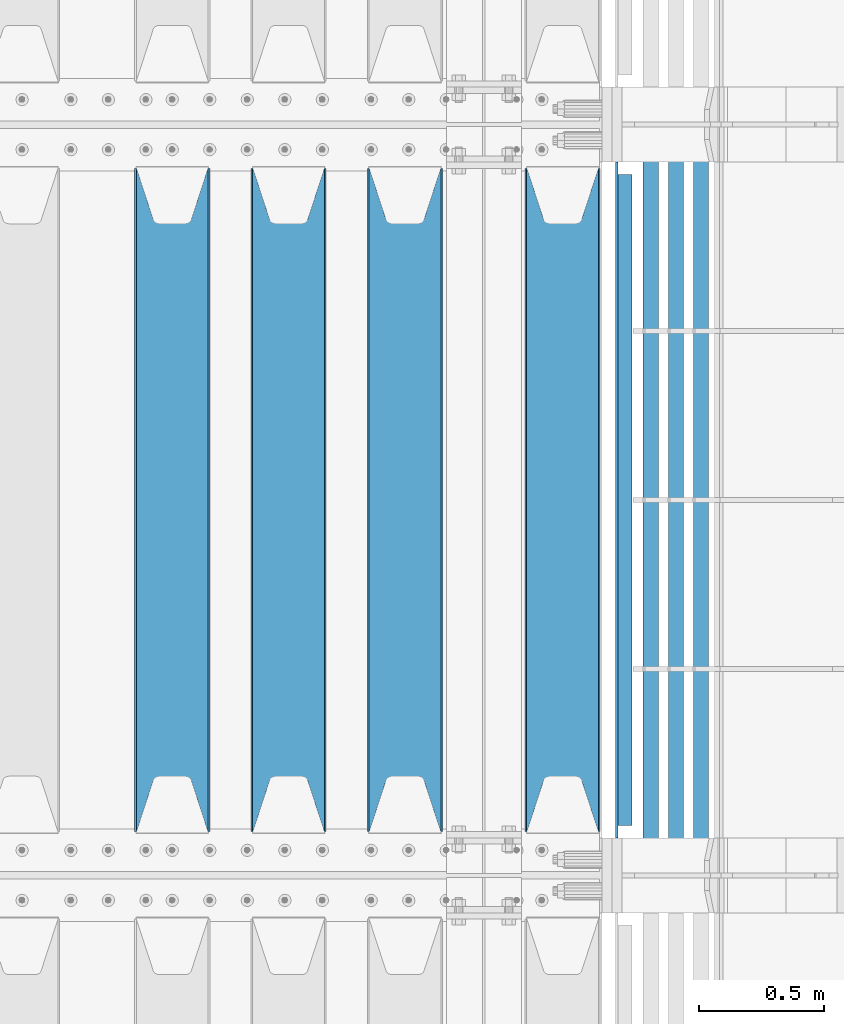
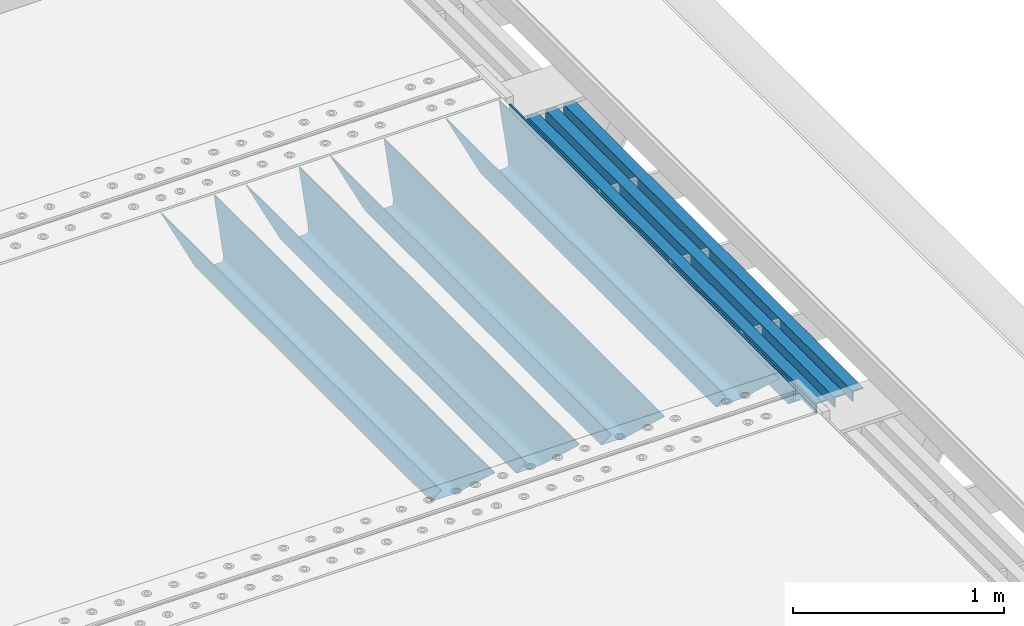
# One storey, part 132 of 247: 8 beams.
"""IFC2X3 building model written with IfcOpenShell, lengths in millimetres."""

from ifc_helpers import new_model, si_unit, frame, origin_with_axes, place, context, subcontext, project, spatial, faceted_brep, material, type_object, element, save


model = new_model("IFC2X3")

# Units and contexts
model_context = context("Model", 3, precision=1e-05, world=origin_with_axes())
body_context = subcontext(model_context, "Body", "Model", "MODEL_VIEW")
ifc_project = project(units=[si_unit("LENGTHUNIT", "METRE", prefix="MILLI"), si_unit("AREAUNIT", "SQUARE_METRE"), si_unit("VOLUMEUNIT", "CUBIC_METRE"), si_unit("MASSUNIT", "GRAM", prefix="KILO"), si_unit("TIMEUNIT", "SECOND"), si_unit("PLANEANGLEUNIT", "RADIAN"), si_unit("SOLIDANGLEUNIT", "STERADIAN"), si_unit("THERMODYNAMICTEMPERATUREUNIT", "DEGREE_CELSIUS"), si_unit("LUMINOUSINTENSITYUNIT", "LUMEN")], contexts=[model_context])

# Site, building, storey
site_placement = place(None, origin_with_axes())
site = spatial("IfcSite", under=ifc_project, at=site_placement, CompositionType="ELEMENT")
building_placement = place(site_placement, origin_with_axes())
building = spatial("IfcBuilding", under=site, at=building_placement, Name="Standard", CompositionType="ELEMENT")
storey_placement = place(building_placement, origin_with_axes())
storey = spatial("IfcBuildingStorey", under=building, at=storey_placement, Name="Undefined", CompositionType="ELEMENT", Elevation=0.0)

# Beams
ifc_material_1 = material(Name="STEEL/S355N")
beam_type_1 = type_object("IfcBeamType", PredefinedType="NOTDEFINED")
beam_1_placement = place(storey_placement, frame((16660.0, 3175.0, -115.0), z_axis=(0.0, 0.0, 1.0), x_axis=(0.0, 1.0, 0.0)))
element("IfcBeam", 1, at=beam_1_placement, inside=storey, type_object=beam_type_1, material=ifc_material_1, context=body_context, shape_type="Brep", body=[
    faceted_brep([(0.0, 150.0, 115.0), (0.0, 143.689999999999, 115.0), (2650.00000000297, 143.689999999999, 115.0), (2650.00000000297, 150.0, 115.0), (2650.00000000297, 142.059565218402, 110.0000000031), (2650.00000000297, 148.369565218403, 110.0000000031), (2441.90079219208, -80.1103600731112, -98.0992078077845), (2437.7588105432, -77.5672621345584, -102.241189456673), (2434.06523489746, -74.4080125315522, -105.934765102404), (2430.91086095089, -70.710272125576, -109.089139048974), (2428.37322971128, -66.5649389910068, -111.626770288588), (2426.51472138054, -62.0739139532889, -113.485278619323), (2425.38102192091, -57.3475956567672, -114.618978078955), (2424.99999999987, -52.5021667386536, -115.0), (2424.99999999987, 52.5021667386536, -115.0), (2425.38102192091, 57.3475956567672, -114.618978078955), (2426.51472138054, 62.0739139532889, -113.485278619323), (2428.37322971128, 66.5649389910068, -111.626770288588), (2430.91086095089, 70.710272125576, -109.089139048974), (2434.06523489746, 74.4080125315522, -105.934765102404), (2437.7588105432, 77.5672621345584, -102.241189456673), (2441.90079219208, 80.1103600731112, -98.0992078077846), (2446.38936140511, 81.9747917625791, -93.6106385947584), (2448.24948500409, 76.2713538057251, -91.7505149957729), (2444.62967112262, 74.76777986261, -95.3703288772456), (2441.28936334126, 72.7168944282894, -98.710636658607), (2438.31067330438, 70.1691124903846, -101.689326695487), (2435.76682334747, 67.1870637758839, -104.233176652398), (2433.72034654133, 63.8440531834895, -106.279653458539), (2432.22154950041, 60.222258798236, -107.778450499454), (2431.30727574265, 56.4107117849089, -108.692724257221), (2430.99999999987, 52.5031078186876, -109.0), (2430.99999999987, -52.5031078186876, -109.0), (2431.30727574265, -56.4107117849089, -108.692724257221), (2432.22154950041, -60.222258798236, -107.778450499454), (2433.72034654133, -63.8440531834895, -106.279653458539), (2435.76682334747, -67.1870637758839, -104.233176652398), (2438.31067330438, -70.1691124903846, -101.689326695487), (2441.28936334126, -72.7168944282894, -98.7106366586071), (2444.62967112262, -74.76777986261, -95.3703288772457), (2448.24948500409, -76.2713538057251, -91.7505149957729), (2650.00000000297, -142.059565218402, 110.0000000031), (2650.00000000297, -148.369565218403, 110.0000000031), (2446.38936140511, -81.9747917625791, -93.6106385947584), (2650.00000000297, -143.689999999999, 115.0), (2650.00000000297, -150.0, 115.0), (0.0, -143.689999999999, 115.0), (0.0, -150.0, 115.0), (0.0, -148.369565218261, 110.000000002663), (203.610638597422, -81.9747917625791, -93.6106385947584), (208.099207810448, -80.1103600731112, -98.0992078077845), (212.241189459336, -77.5672621345584, -102.241189456673), (215.934765105068, -74.4080125315522, -105.934765102404), (219.089139051637, -70.710272125576, -109.089139048974), (221.626770291251, -66.5649389910068, -111.626770288588), (223.485278621985, -62.0739139532889, -113.485278619323), (224.618978081617, -57.3475956567672, -114.618978078955), (225.000000002663, -52.5021667386536, -115.0), (225.000000002663, 52.5021667386536, -115.0), (224.618978081617, 57.3475956567672, -114.618978078955), (223.485278621985, 62.0739139532889, -113.485278619323), (221.626770291251, 66.5649389910068, -111.626770288588), (219.089139051637, 70.710272125576, -109.089139048974), (215.934765105068, 74.4080125315522, -105.934765102404), (212.241189459336, 77.5672621345584, -102.241189456673), (208.099207810448, 80.1103600731112, -98.0992078077846), (203.610638597422, 81.9747917625791, -93.6106385947584), (0.0, 148.369565218261, 110.000000002663), (0.0, 142.05956521826, 110.000000002663), (201.750514998436, 76.2713538057251, -91.7505149957729), (205.370328879908, 74.76777986261, -95.3703288772456), (208.710636661271, 72.7168944282894, -98.710636658607), (211.68932669815, 70.1691124903846, -101.689326695487), (214.233176655061, 67.1870637758839, -104.233176652398), (216.279653461202, 63.8440531834895, -106.279653458539), (217.778450502117, 60.222258798236, -107.778450499454), (218.692724259885, 56.4107117849089, -108.692724257221), (219.000000002663, 52.5031078186876, -109.0), (219.000000002663, -52.5031078186876, -109.0), (218.692724259885, -56.4107117849089, -108.692724257221), (217.778450502117, -60.222258798236, -107.778450499454), (216.279653461202, -63.8440531834895, -106.279653458539), (214.233176655061, -67.1870637758839, -104.233176652398), (211.68932669815, -70.1691124903846, -101.689326695487), (208.710636661271, -72.7168944282894, -98.7106366586071), (205.370328879908, -74.76777986261, -95.3703288772457), (201.750514998436, -76.2713538057251, -91.7505149957729), (0.0, -142.05956521826, 110.000000002663)], [[[0, 1, 2, 3]], [[3, 2, 4, 5]], [[6, 7, 8, 9, 10, 11, 12, 13, 14, 15, 16, 17, 18, 19, 20, 21, 22, 5, 4, 23, 24, 25, 26, 27, 28, 29, 30, 31, 32, 33, 34, 35, 36, 37, 38, 39, 40, 41, 42, 43]], [[44, 45, 42, 41]], [[46, 47, 45, 44]], [[43, 42, 45, 47, 48, 49]], [[6, 43, 49, 50]], [[7, 6, 50, 51]], [[8, 7, 51, 52]], [[9, 8, 52, 53]], [[10, 9, 53, 54]], [[11, 10, 54, 55]], [[12, 11, 55, 56]], [[13, 12, 56, 57]], [[14, 13, 57, 58]], [[15, 14, 58, 59]], [[16, 15, 59, 60]], [[17, 16, 60, 61]], [[18, 17, 61, 62]], [[19, 18, 62, 63]], [[20, 19, 63, 64]], [[21, 20, 64, 65]], [[22, 21, 65, 66]], [[0, 3, 5, 22, 66, 67]], [[1, 0, 67, 68]], [[23, 4, 2, 1, 68, 69]], [[24, 23, 69, 70]], [[25, 24, 70, 71]], [[26, 25, 71, 72]], [[27, 26, 72, 73]], [[28, 27, 73, 74]], [[29, 28, 74, 75]], [[30, 29, 75, 76]], [[31, 30, 76, 77]], [[32, 31, 77, 78]], [[33, 32, 78, 79]], [[34, 33, 79, 80]], [[35, 34, 80, 81]], [[36, 35, 81, 82]], [[37, 36, 82, 83]], [[38, 37, 83, 84]], [[39, 38, 84, 85]], [[40, 39, 85, 86]], [[46, 44, 41, 40, 86, 87]], [[47, 46, 87, 48]], [[86, 85, 84, 83, 82, 81, 80, 79, 78, 77, 76, 75, 74, 73, 72, 71, 70, 69, 68, 67, 66, 65, 64, 63, 62, 61, 60, 59, 58, 57, 56, 55, 54, 53, 52, 51, 50, 49, 48, 87]]]),
])
beam_2_placement = place(storey_placement, frame((16030.0, 3175.0, -115.0), z_axis=(0.0, 0.0, 1.0), x_axis=(0.0, 1.0, 0.0)))
element("IfcBeam", 2, at=beam_2_placement, inside=storey, type_object=beam_type_1, material=ifc_material_1, context=body_context, shape_type="Brep", body=[
    faceted_brep([(0.0, 150.0, 115.0), (0.0, 143.689999999999, 115.0), (2650.00000000297, 143.689999999999, 115.0), (2650.00000000297, 150.0, 115.0), (2650.00000000297, 142.059565218402, 110.0000000031), (2650.00000000297, 148.369565218403, 110.0000000031), (2441.90079219208, -80.1103600731112, -98.0992078077845), (2437.7588105432, -77.5672621345584, -102.241189456673), (2434.06523489746, -74.4080125315522, -105.934765102404), (2430.91086095089, -70.710272125576, -109.089139048974), (2428.37322971128, -66.5649389910068, -111.626770288588), (2426.51472138054, -62.0739139532889, -113.485278619323), (2425.38102192091, -57.3475956567672, -114.618978078955), (2424.99999999987, -52.5021667386536, -115.0), (2424.99999999987, 52.5021667386536, -115.0), (2425.38102192091, 57.3475956567672, -114.618978078955), (2426.51472138054, 62.0739139532889, -113.485278619323), (2428.37322971128, 66.5649389910068, -111.626770288588), (2430.91086095089, 70.710272125576, -109.089139048974), (2434.06523489746, 74.4080125315522, -105.934765102404), (2437.7588105432, 77.5672621345584, -102.241189456673), (2441.90079219208, 80.1103600731112, -98.0992078077846), (2446.38936140511, 81.9747917625791, -93.6106385947584), (2448.24948500409, 76.2713538057251, -91.7505149957729), (2444.62967112262, 74.76777986261, -95.3703288772456), (2441.28936334126, 72.7168944282894, -98.710636658607), (2438.31067330438, 70.1691124903846, -101.689326695487), (2435.76682334747, 67.1870637758839, -104.233176652398), (2433.72034654133, 63.8440531834895, -106.279653458539), (2432.22154950041, 60.222258798236, -107.778450499454), (2431.30727574265, 56.4107117849089, -108.692724257221), (2430.99999999987, 52.5031078186876, -109.0), (2430.99999999987, -52.5031078186876, -109.0), (2431.30727574265, -56.4107117849089, -108.692724257221), (2432.22154950041, -60.222258798236, -107.778450499454), (2433.72034654133, -63.8440531834895, -106.279653458539), (2435.76682334747, -67.1870637758839, -104.233176652398), (2438.31067330438, -70.1691124903846, -101.689326695487), (2441.28936334126, -72.7168944282894, -98.7106366586071), (2444.62967112262, -74.76777986261, -95.3703288772457), (2448.24948500409, -76.2713538057251, -91.7505149957729), (2650.00000000297, -142.059565218402, 110.0000000031), (2650.00000000297, -148.369565218403, 110.0000000031), (2446.38936140511, -81.9747917625791, -93.6106385947584), (2650.00000000297, -143.689999999999, 115.0), (2650.00000000297, -150.0, 115.0), (0.0, -143.689999999999, 115.0), (0.0, -150.0, 115.0), (0.0, -148.369565218261, 110.000000002663), (203.610638597422, -81.9747917625791, -93.6106385947584), (208.099207810448, -80.1103600731112, -98.0992078077845), (212.241189459336, -77.5672621345584, -102.241189456673), (215.934765105068, -74.4080125315522, -105.934765102404), (219.089139051637, -70.710272125576, -109.089139048974), (221.626770291251, -66.5649389910068, -111.626770288588), (223.485278621985, -62.0739139532889, -113.485278619323), (224.618978081617, -57.3475956567672, -114.618978078955), (225.000000002663, -52.5021667386536, -115.0), (225.000000002663, 52.5021667386536, -115.0), (224.618978081617, 57.3475956567672, -114.618978078955), (223.485278621985, 62.0739139532889, -113.485278619323), (221.626770291251, 66.5649389910068, -111.626770288588), (219.089139051637, 70.710272125576, -109.089139048974), (215.934765105068, 74.4080125315522, -105.934765102404), (212.241189459336, 77.5672621345584, -102.241189456673), (208.099207810448, 80.1103600731112, -98.0992078077846), (203.610638597422, 81.9747917625791, -93.6106385947584), (0.0, 148.369565218261, 110.000000002663), (0.0, 142.05956521826, 110.000000002663), (201.750514998436, 76.2713538057251, -91.7505149957729), (205.370328879908, 74.76777986261, -95.3703288772456), (208.710636661271, 72.7168944282894, -98.710636658607), (211.68932669815, 70.1691124903846, -101.689326695487), (214.233176655061, 67.1870637758839, -104.233176652398), (216.279653461202, 63.8440531834895, -106.279653458539), (217.778450502117, 60.222258798236, -107.778450499454), (218.692724259885, 56.4107117849089, -108.692724257221), (219.000000002663, 52.5031078186876, -109.0), (219.000000002663, -52.5031078186876, -109.0), (218.692724259885, -56.4107117849089, -108.692724257221), (217.778450502117, -60.222258798236, -107.778450499454), (216.279653461202, -63.8440531834895, -106.279653458539), (214.233176655061, -67.1870637758839, -104.233176652398), (211.68932669815, -70.1691124903846, -101.689326695487), (208.710636661271, -72.7168944282894, -98.7106366586071), (205.370328879908, -74.76777986261, -95.3703288772457), (201.750514998436, -76.2713538057251, -91.7505149957729), (0.0, -142.05956521826, 110.000000002663)], [[[0, 1, 2, 3]], [[3, 2, 4, 5]], [[6, 7, 8, 9, 10, 11, 12, 13, 14, 15, 16, 17, 18, 19, 20, 21, 22, 5, 4, 23, 24, 25, 26, 27, 28, 29, 30, 31, 32, 33, 34, 35, 36, 37, 38, 39, 40, 41, 42, 43]], [[44, 45, 42, 41]], [[46, 47, 45, 44]], [[43, 42, 45, 47, 48, 49]], [[6, 43, 49, 50]], [[7, 6, 50, 51]], [[8, 7, 51, 52]], [[9, 8, 52, 53]], [[10, 9, 53, 54]], [[11, 10, 54, 55]], [[12, 11, 55, 56]], [[13, 12, 56, 57]], [[14, 13, 57, 58]], [[15, 14, 58, 59]], [[16, 15, 59, 60]], [[17, 16, 60, 61]], [[18, 17, 61, 62]], [[19, 18, 62, 63]], [[20, 19, 63, 64]], [[21, 20, 64, 65]], [[22, 21, 65, 66]], [[0, 3, 5, 22, 66, 67]], [[1, 0, 67, 68]], [[23, 4, 2, 1, 68, 69]], [[24, 23, 69, 70]], [[25, 24, 70, 71]], [[26, 25, 71, 72]], [[27, 26, 72, 73]], [[28, 27, 73, 74]], [[29, 28, 74, 75]], [[30, 29, 75, 76]], [[31, 30, 76, 77]], [[32, 31, 77, 78]], [[33, 32, 78, 79]], [[34, 33, 79, 80]], [[35, 34, 80, 81]], [[36, 35, 81, 82]], [[37, 36, 82, 83]], [[38, 37, 83, 84]], [[39, 38, 84, 85]], [[40, 39, 85, 86]], [[46, 44, 41, 40, 86, 87]], [[47, 46, 87, 48]], [[86, 85, 84, 83, 82, 81, 80, 79, 78, 77, 76, 75, 74, 73, 72, 71, 70, 69, 68, 67, 66, 65, 64, 63, 62, 61, 60, 59, 58, 57, 56, 55, 54, 53, 52, 51, 50, 49, 48, 87]]]),
])
beam_3_placement = place(storey_placement, frame((15565.0, 3175.0, -115.0), z_axis=(0.0, 0.0, 1.0), x_axis=(0.0, 1.0, 0.0)))
element("IfcBeam", 3, at=beam_3_placement, inside=storey, type_object=beam_type_1, material=ifc_material_1, context=body_context, shape_type="Brep", body=[
    faceted_brep([(0.0, 150.0, 115.0), (0.0, 143.689999999999, 115.0), (2650.00000000297, 143.689999999999, 115.0), (2650.00000000297, 150.0, 115.0), (2650.00000000297, 142.059565218402, 110.0000000031), (2650.00000000297, 148.369565218403, 110.0000000031), (2441.90079219208, -80.1103600731112, -98.0992078077845), (2437.7588105432, -77.5672621345584, -102.241189456673), (2434.06523489746, -74.4080125315522, -105.934765102404), (2430.91086095089, -70.710272125576, -109.089139048974), (2428.37322971128, -66.5649389910068, -111.626770288588), (2426.51472138054, -62.0739139532889, -113.485278619323), (2425.38102192091, -57.3475956567672, -114.618978078955), (2424.99999999987, -52.5021667386536, -115.0), (2424.99999999987, 52.5021667386536, -115.0), (2425.38102192091, 57.3475956567672, -114.618978078955), (2426.51472138054, 62.0739139532889, -113.485278619323), (2428.37322971128, 66.5649389910068, -111.626770288588), (2430.91086095089, 70.710272125576, -109.089139048974), (2434.06523489746, 74.4080125315522, -105.934765102404), (2437.7588105432, 77.5672621345584, -102.241189456673), (2441.90079219208, 80.1103600731112, -98.0992078077846), (2446.38936140511, 81.9747917625791, -93.6106385947584), (2448.24948500409, 76.2713538057251, -91.7505149957729), (2444.62967112262, 74.76777986261, -95.3703288772456), (2441.28936334126, 72.7168944282894, -98.710636658607), (2438.31067330438, 70.1691124903846, -101.689326695487), (2435.76682334747, 67.1870637758839, -104.233176652398), (2433.72034654133, 63.8440531834895, -106.279653458539), (2432.22154950041, 60.222258798236, -107.778450499454), (2431.30727574265, 56.4107117849089, -108.692724257221), (2430.99999999987, 52.5031078186876, -109.0), (2430.99999999987, -52.5031078186876, -109.0), (2431.30727574265, -56.4107117849089, -108.692724257221), (2432.22154950041, -60.222258798236, -107.778450499454), (2433.72034654133, -63.8440531834895, -106.279653458539), (2435.76682334747, -67.1870637758839, -104.233176652398), (2438.31067330438, -70.1691124903846, -101.689326695487), (2441.28936334126, -72.7168944282894, -98.7106366586071), (2444.62967112262, -74.76777986261, -95.3703288772457), (2448.24948500409, -76.2713538057251, -91.7505149957729), (2650.00000000297, -142.059565218402, 110.0000000031), (2650.00000000297, -148.369565218403, 110.0000000031), (2446.38936140511, -81.9747917625791, -93.6106385947584), (2650.00000000297, -143.689999999999, 115.0), (2650.00000000297, -150.0, 115.0), (0.0, -143.689999999999, 115.0), (0.0, -150.0, 115.0), (0.0, -148.369565218261, 110.000000002663), (203.610638597422, -81.9747917625791, -93.6106385947584), (208.099207810448, -80.1103600731112, -98.0992078077845), (212.241189459336, -77.5672621345584, -102.241189456673), (215.934765105068, -74.4080125315522, -105.934765102404), (219.089139051637, -70.710272125576, -109.089139048974), (221.626770291251, -66.5649389910068, -111.626770288588), (223.485278621985, -62.0739139532889, -113.485278619323), (224.618978081617, -57.3475956567672, -114.618978078955), (225.000000002663, -52.5021667386536, -115.0), (225.000000002663, 52.5021667386536, -115.0), (224.618978081617, 57.3475956567672, -114.618978078955), (223.485278621985, 62.0739139532889, -113.485278619323), (221.626770291251, 66.5649389910068, -111.626770288588), (219.089139051637, 70.710272125576, -109.089139048974), (215.934765105068, 74.4080125315522, -105.934765102404), (212.241189459336, 77.5672621345584, -102.241189456673), (208.099207810448, 80.1103600731112, -98.0992078077846), (203.610638597422, 81.9747917625791, -93.6106385947584), (0.0, 148.369565218261, 110.000000002663), (0.0, 142.05956521826, 110.000000002663), (201.750514998436, 76.2713538057251, -91.7505149957729), (205.370328879908, 74.76777986261, -95.3703288772456), (208.710636661271, 72.7168944282894, -98.710636658607), (211.68932669815, 70.1691124903846, -101.689326695487), (214.233176655061, 67.1870637758839, -104.233176652398), (216.279653461202, 63.8440531834895, -106.279653458539), (217.778450502117, 60.222258798236, -107.778450499454), (218.692724259885, 56.4107117849089, -108.692724257221), (219.000000002663, 52.5031078186876, -109.0), (219.000000002663, -52.5031078186876, -109.0), (218.692724259885, -56.4107117849089, -108.692724257221), (217.778450502117, -60.222258798236, -107.778450499454), (216.279653461202, -63.8440531834895, -106.279653458539), (214.233176655061, -67.1870637758839, -104.233176652398), (211.68932669815, -70.1691124903846, -101.689326695487), (208.710636661271, -72.7168944282894, -98.7106366586071), (205.370328879908, -74.76777986261, -95.3703288772457), (201.750514998436, -76.2713538057251, -91.7505149957729), (0.0, -142.05956521826, 110.000000002663)], [[[0, 1, 2, 3]], [[3, 2, 4, 5]], [[6, 7, 8, 9, 10, 11, 12, 13, 14, 15, 16, 17, 18, 19, 20, 21, 22, 5, 4, 23, 24, 25, 26, 27, 28, 29, 30, 31, 32, 33, 34, 35, 36, 37, 38, 39, 40, 41, 42, 43]], [[44, 45, 42, 41]], [[46, 47, 45, 44]], [[43, 42, 45, 47, 48, 49]], [[6, 43, 49, 50]], [[7, 6, 50, 51]], [[8, 7, 51, 52]], [[9, 8, 52, 53]], [[10, 9, 53, 54]], [[11, 10, 54, 55]], [[12, 11, 55, 56]], [[13, 12, 56, 57]], [[14, 13, 57, 58]], [[15, 14, 58, 59]], [[16, 15, 59, 60]], [[17, 16, 60, 61]], [[18, 17, 61, 62]], [[19, 18, 62, 63]], [[20, 19, 63, 64]], [[21, 20, 64, 65]], [[22, 21, 65, 66]], [[0, 3, 5, 22, 66, 67]], [[1, 0, 67, 68]], [[23, 4, 2, 1, 68, 69]], [[24, 23, 69, 70]], [[25, 24, 70, 71]], [[26, 25, 71, 72]], [[27, 26, 72, 73]], [[28, 27, 73, 74]], [[29, 28, 74, 75]], [[30, 29, 75, 76]], [[31, 30, 76, 77]], [[32, 31, 77, 78]], [[33, 32, 78, 79]], [[34, 33, 79, 80]], [[35, 34, 80, 81]], [[36, 35, 81, 82]], [[37, 36, 82, 83]], [[38, 37, 83, 84]], [[39, 38, 84, 85]], [[40, 39, 85, 86]], [[46, 44, 41, 40, 86, 87]], [[47, 46, 87, 48]], [[86, 85, 84, 83, 82, 81, 80, 79, 78, 77, 76, 75, 74, 73, 72, 71, 70, 69, 68, 67, 66, 65, 64, 63, 62, 61, 60, 59, 58, 57, 56, 55, 54, 53, 52, 51, 50, 49, 48, 87]]]),
])
beam_4_placement = place(storey_placement, frame((15100.0, 3175.0, -115.0), z_axis=(0.0, 0.0, 1.0), x_axis=(0.0, 1.0, 0.0)))
element("IfcBeam", 4, at=beam_4_placement, inside=storey, type_object=beam_type_1, material=ifc_material_1, context=body_context, shape_type="Brep", body=[
    faceted_brep([(0.0, 150.0, 115.0), (0.0, 143.689999999999, 115.0), (2650.00000000297, 143.689999999999, 115.0), (2650.00000000297, 150.0, 115.0), (2650.00000000297, 142.059565218402, 110.0000000031), (2650.00000000297, 148.369565218403, 110.0000000031), (2441.90079219208, -80.1103600731112, -98.0992078077845), (2437.7588105432, -77.5672621345584, -102.241189456673), (2434.06523489746, -74.4080125315522, -105.934765102404), (2430.91086095089, -70.710272125576, -109.089139048974), (2428.37322971128, -66.5649389910068, -111.626770288588), (2426.51472138054, -62.0739139532889, -113.485278619323), (2425.38102192091, -57.3475956567672, -114.618978078955), (2424.99999999987, -52.5021667386536, -115.0), (2424.99999999987, 52.5021667386536, -115.0), (2425.38102192091, 57.3475956567672, -114.618978078955), (2426.51472138054, 62.0739139532889, -113.485278619323), (2428.37322971128, 66.5649389910068, -111.626770288588), (2430.91086095089, 70.710272125576, -109.089139048974), (2434.06523489746, 74.4080125315522, -105.934765102404), (2437.7588105432, 77.5672621345584, -102.241189456673), (2441.90079219208, 80.1103600731112, -98.0992078077846), (2446.38936140511, 81.9747917625791, -93.6106385947584), (2448.24948500409, 76.2713538057251, -91.7505149957729), (2444.62967112262, 74.76777986261, -95.3703288772456), (2441.28936334126, 72.7168944282894, -98.710636658607), (2438.31067330438, 70.1691124903846, -101.689326695487), (2435.76682334747, 67.1870637758839, -104.233176652398), (2433.72034654133, 63.8440531834895, -106.279653458539), (2432.22154950041, 60.222258798236, -107.778450499454), (2431.30727574265, 56.4107117849089, -108.692724257221), (2430.99999999987, 52.5031078186876, -109.0), (2430.99999999987, -52.5031078186876, -109.0), (2431.30727574265, -56.4107117849089, -108.692724257221), (2432.22154950041, -60.222258798236, -107.778450499454), (2433.72034654133, -63.8440531834895, -106.279653458539), (2435.76682334747, -67.1870637758839, -104.233176652398), (2438.31067330438, -70.1691124903846, -101.689326695487), (2441.28936334126, -72.7168944282894, -98.7106366586071), (2444.62967112262, -74.76777986261, -95.3703288772457), (2448.24948500409, -76.2713538057251, -91.7505149957729), (2650.00000000297, -142.059565218402, 110.0000000031), (2650.00000000297, -148.369565218403, 110.0000000031), (2446.38936140511, -81.9747917625791, -93.6106385947584), (2650.00000000297, -143.689999999999, 115.0), (2650.00000000297, -150.0, 115.0), (0.0, -143.689999999999, 115.0), (0.0, -150.0, 115.0), (0.0, -148.369565218261, 110.000000002663), (203.610638597422, -81.9747917625791, -93.6106385947584), (208.099207810448, -80.1103600731112, -98.0992078077845), (212.241189459336, -77.5672621345584, -102.241189456673), (215.934765105068, -74.4080125315522, -105.934765102404), (219.089139051637, -70.710272125576, -109.089139048974), (221.626770291251, -66.5649389910068, -111.626770288588), (223.485278621985, -62.0739139532889, -113.485278619323), (224.618978081617, -57.3475956567672, -114.618978078955), (225.000000002663, -52.5021667386536, -115.0), (225.000000002663, 52.5021667386536, -115.0), (224.618978081617, 57.3475956567672, -114.618978078955), (223.485278621985, 62.0739139532889, -113.485278619323), (221.626770291251, 66.5649389910068, -111.626770288588), (219.089139051637, 70.710272125576, -109.089139048974), (215.934765105068, 74.4080125315522, -105.934765102404), (212.241189459336, 77.5672621345584, -102.241189456673), (208.099207810448, 80.1103600731112, -98.0992078077846), (203.610638597422, 81.9747917625791, -93.6106385947584), (0.0, 148.369565218261, 110.000000002663), (0.0, 142.05956521826, 110.000000002663), (201.750514998436, 76.2713538057251, -91.7505149957729), (205.370328879908, 74.76777986261, -95.3703288772456), (208.710636661271, 72.7168944282894, -98.710636658607), (211.68932669815, 70.1691124903846, -101.689326695487), (214.233176655061, 67.1870637758839, -104.233176652398), (216.279653461202, 63.8440531834895, -106.279653458539), (217.778450502117, 60.222258798236, -107.778450499454), (218.692724259885, 56.4107117849089, -108.692724257221), (219.000000002663, 52.5031078186876, -109.0), (219.000000002663, -52.5031078186876, -109.0), (218.692724259885, -56.4107117849089, -108.692724257221), (217.778450502117, -60.222258798236, -107.778450499454), (216.279653461202, -63.8440531834895, -106.279653458539), (214.233176655061, -67.1870637758839, -104.233176652398), (211.68932669815, -70.1691124903846, -101.689326695487), (208.710636661271, -72.7168944282894, -98.7106366586071), (205.370328879908, -74.76777986261, -95.3703288772457), (201.750514998436, -76.2713538057251, -91.7505149957729), (0.0, -142.05956521826, 110.000000002663)], [[[0, 1, 2, 3]], [[3, 2, 4, 5]], [[6, 7, 8, 9, 10, 11, 12, 13, 14, 15, 16, 17, 18, 19, 20, 21, 22, 5, 4, 23, 24, 25, 26, 27, 28, 29, 30, 31, 32, 33, 34, 35, 36, 37, 38, 39, 40, 41, 42, 43]], [[44, 45, 42, 41]], [[46, 47, 45, 44]], [[43, 42, 45, 47, 48, 49]], [[6, 43, 49, 50]], [[7, 6, 50, 51]], [[8, 7, 51, 52]], [[9, 8, 52, 53]], [[10, 9, 53, 54]], [[11, 10, 54, 55]], [[12, 11, 55, 56]], [[13, 12, 56, 57]], [[14, 13, 57, 58]], [[15, 14, 58, 59]], [[16, 15, 59, 60]], [[17, 16, 60, 61]], [[18, 17, 61, 62]], [[19, 18, 62, 63]], [[20, 19, 63, 64]], [[21, 20, 64, 65]], [[22, 21, 65, 66]], [[0, 3, 5, 22, 66, 67]], [[1, 0, 67, 68]], [[23, 4, 2, 1, 68, 69]], [[24, 23, 69, 70]], [[25, 24, 70, 71]], [[26, 25, 71, 72]], [[27, 26, 72, 73]], [[28, 27, 73, 74]], [[29, 28, 74, 75]], [[30, 29, 75, 76]], [[31, 30, 76, 77]], [[32, 31, 77, 78]], [[33, 32, 78, 79]], [[34, 33, 79, 80]], [[35, 34, 80, 81]], [[36, 35, 81, 82]], [[37, 36, 82, 83]], [[38, 37, 83, 84]], [[39, 38, 84, 85]], [[40, 39, 85, 86]], [[46, 44, 41, 40, 86, 87]], [[47, 46, 87, 48]], [[86, 85, 84, 83, 82, 81, 80, 79, 78, 77, 76, 75, 74, 73, 72, 71, 70, 69, 68, 67, 66, 65, 64, 63, 62, 61, 60, 59, 58, 57, 56, 55, 54, 53, 52, 51, 50, 49, 48, 87]]]),
])
ifc_material_2 = material(Name="STEEL/S355J2")
beam_type_2 = type_object("IfcBeamType", PredefinedType="NOTDEFINED")
beam_5_placement = place(storey_placement, frame((16904.5025260065, 3150.0, -124.999999999985), z_axis=(0.0, 0.0, 1.0), x_axis=(0.0, 1.0, 0.0)))
element("IfcBeam", 5, at=beam_5_placement, inside=storey, type_object=beam_type_2, material=ifc_material_2, context=body_context, shape_type="Brep", body=[
    faceted_brep([(2700.0, 22.5, -15.0), (2684.54915028125, 22.5, -17.4471741852423), (2684.54915028125, 32.5, -17.4471741852423), (2700.0, 32.5, -15.0), (2670.61073738538, 22.5, -24.5491502812526), (2670.61073738538, 32.5, -24.5491502812526), (2659.54915028125, 22.5, -35.6107373853764), (2659.54915028125, 32.5, -35.6107373853764), (2652.44717418524, 22.5, -49.5491502812526), (2652.44717418524, 32.5, -49.5491502812526), (2651.58384440324, -32.5, -55.0), (2650.0, -32.5, -65.0), (2650.0, 32.5, -65.0), (2651.58384440324, 22.5, -55.0), (0.0, 32.5, 65.0), (0.0, 22.5, 65.0), (2700.0, 22.5, 65.0), (2700.0, 32.5, 65.0), (0.0, 32.5, -15.0), (0.0, 22.5, -15.0), (15.4508497187474, 32.5, -17.4471741852423), (15.4508497187474, 22.5, -17.4471741852423), (29.3892626146236, 32.5, -24.5491502812526), (29.3892626146236, 22.5, -24.5491502812526), (40.4508497187473, 32.5, -35.6107373853763), (40.4508497187473, 22.5, -35.6107373853763), (47.5528258147577, 32.5, -49.5491502812526), (47.5528258147577, 22.5, -49.5491502812526), (50.0, -32.5, -65.0), (48.4161555967548, -32.5, -55.0), (48.4161555967548, 22.5, -55.0), (50.0, 32.5, -65.0)], [[[0, 1, 2, 3]], [[4, 5, 2, 1]], [[6, 7, 5, 4]], [[8, 9, 7, 6]], [[10, 11, 12, 9, 8, 13]], [[14, 15, 16, 17]], [[15, 14, 18, 19]], [[19, 18, 20, 21]], [[21, 20, 22, 23]], [[23, 22, 24, 25]], [[25, 24, 26, 27]], [[28, 29, 30, 27, 26, 31]], [[30, 29, 10, 13]], [[16, 15, 19, 21, 23, 25, 27, 30, 13, 8, 6, 4, 1, 0]], [[17, 16, 0, 3]], [[5, 7, 9, 12, 31, 26, 24, 22, 20, 18, 14, 17, 3, 2]], [[28, 31, 12, 11]], [[29, 28, 11, 10]]]),
])
beam_type_3 = type_object("IfcBeamType", PredefinedType="NOTDEFINED")
for number, where, z_axis, x_axis in (
    (6, (17212.0025260169, 5869.9999003886, -209.999999999563), (0.0, 0.0, -1.0), (0.0, -0.999999999999548, -9.5100000000016e-07)),
    (7, (17112.0025260169, 5869.99990038863, -209.999999999563), (0.0, 0.0, -1.0), (0.0, -0.999999999999548, -9.5100000000016e-07)),
    (8, (17012.0025260162, 5870.00000231317, -209.999999999622), (0.0, 0.0, -1.0), (0.0, -0.999999999999548, -9.5100000000016e-07)),
):
    element("IfcBeam", number, at=place(storey_placement, frame(where, z_axis=z_axis, x_axis=x_axis)), inside=storey, type_object=beam_type_3, material=ifc_material_2, context=body_context, shape_type="Brep", body=[
        faceted_brep([(4.54747350886464e-13, 30.0, -30.0), (4.54747350886464e-13, 30.0, 30.0000000000001), (2740.00017042501, 30.0, 30.0000000000001), (2740.00017042501, 30.0, -29.9999999999999), (4.54747350886464e-13, 24.0, 30.0), (2740.00017042501, 24.0, 30.0), (4.54747350886464e-13, 24.0, -24.0), (2740.00017042501, 24.0, -24.0), (4.54747350886464e-13, -30.0, -24.0), (2740.00017042501, -30.0, -24.0), (4.54747350886464e-13, -30.0, -30.0), (2740.00017042501, -30.0, -30.0)], [[[0, 1, 2, 3]], [[1, 4, 5, 2]], [[4, 6, 7, 5]], [[6, 8, 9, 7]], [[8, 10, 11, 9]], [[10, 0, 3, 11]], [[5, 7, 9, 11, 3, 2]], [[10, 8, 6, 4, 1, 0]]]),
    ])

save(model, "model.ifc")
